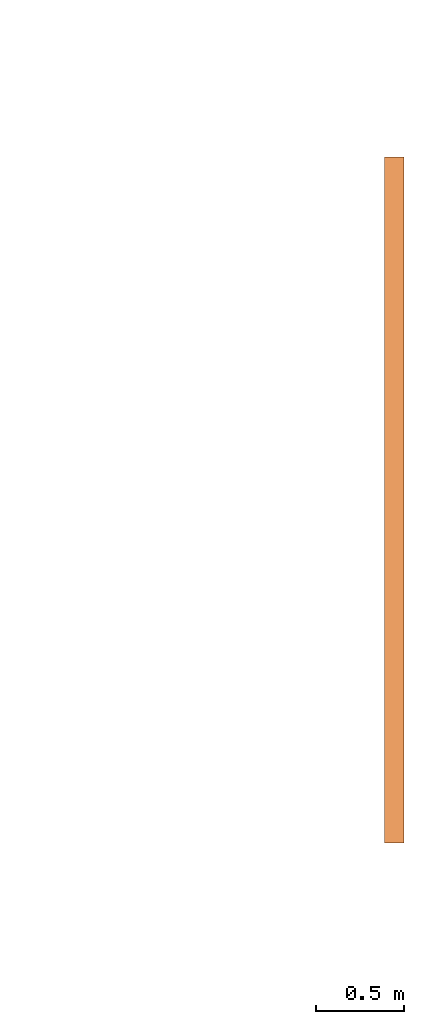
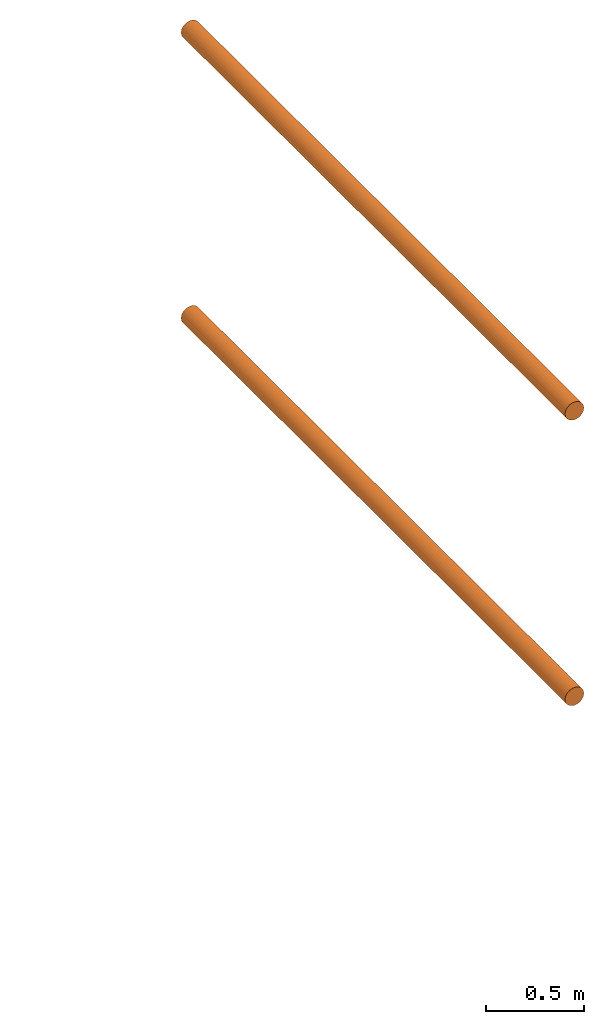
# One storey, part 5 of 5: 2 proxies.
"""IFC2X3 building model written with IfcOpenShell, lengths in metres."""

from ifc_helpers import new_model, entity, si_unit, converted_unit, frame, origin, place, context, subcontext, project, spatial, faceted_brep, material, element, save


model = new_model("IFC2X3")

# Units and contexts
model_context = context("Model", 3, precision=1e-05, world=origin())
body_context = subcontext(model_context, "Body", "Model", "MODEL_VIEW")
ifc_project = project(units=[si_unit("LENGTHUNIT", "METRE"), si_unit("AREAUNIT", "SQUARE_METRE"), si_unit("VOLUMEUNIT", "CUBIC_METRE"), converted_unit("PLANEANGLEUNIT", "DEGREE", entity("IfcPlaneAngleMeasure", 0.0174532925199433), si_unit("PLANEANGLEUNIT", "RADIAN"), dimensions=[0, 0, 0, 0, 0, 0, 0])], contexts=[model_context])

# Site, building, storey
site_placement = place(None, frame((2.0, 7.0, 6.0)))
site = spatial("IfcSite", under=ifc_project, at=site_placement, CompositionType="ELEMENT")
building_placement = place(site_placement, origin())
building = spatial("IfcBuilding", under=site, at=building_placement, Name="de", CompositionType="ELEMENT")
storey_placement = place(building_placement, frame((0.0, 0.0, 4.0)))
storey = spatial("IfcBuildingStorey", under=building, at=storey_placement, CompositionType="ELEMENT", Elevation=4.0)

# Proxies
ifc_material_1 = material()
proxy_1_placement = place(storey_placement, frame((7.751510837974278, 2.468964102564105, 2.833089238362359)))
element("IfcBuildingElementProxy", 1, at=proxy_1_placement, inside=storey, material=ifc_material_1, context=body_context, shape_type="Brep", body=[
    faceted_brep([(0.11, 2.273736754432321e-16, 0.05500000000000001), (0.1081259204458988, 2.273736754432321e-16, 0.04076495251936138), (0.1026313972081441, 2.273736754432321e-16, 0.02750000000000001), (0.09389087296526015, 2.273736754432321e-16, 0.01610912703473991), (0.08250000000000002, 2.273736754432321e-16, 0.007368602791855885), (0.06923504748063866, 2.273736754432321e-16, 0.00187407955410125), (0.05500000000000003, 2.273736754432321e-16, 0.0), (0.0407649525193614, 2.273736754432321e-16, 0.001874079554101236), (0.02750000000000004, 2.273736754432321e-16, 0.007368602791855849), (0.01610912703473991, 2.273736754432321e-16, 0.01610912703473987), (0.007368602791855913, 2.273736754432321e-16, 0.02749999999999994), (0.001874079554101257, 2.273736754432321e-16, 0.04076495251936132), (0.0, 2.273736754432321e-16, 0.05499999999999995), (0.001874079554101236, 2.273736754432321e-16, 0.06923504748063862), (0.007368602791855849, 2.273736754432321e-16, 0.08249999999999996), (0.01610912703473984, 2.273736754432321e-16, 0.09389087296526008), (0.02749999999999994, 2.273736754432321e-16, 0.1026313972081441), (0.04076495251936132, 2.273736754432321e-16, 0.1081259204458988), (0.055, 2.273736754432321e-16, 0.11), (0.06923504748063865, 2.273736754432321e-16, 0.1081259204458988), (0.0825, 2.273736754432321e-16, 0.1026313972081441), (0.09389087296526012, 2.273736754432321e-16, 0.09389087296526012), (0.1026313972081441, 2.273736754432321e-16, 0.0825), (0.1081259204458988, 2.273736754432321e-16, 0.06923504748063866), (0.11, 3.9, 0.055), (0.1081259204458988, 3.9, 0.06923504748063866), (0.1026313972081441, 3.9, 0.0825), (0.09389087296526012, 3.9, 0.09389087296526012), (0.0825, 3.9, 0.1026313972081441), (0.06923504748063865, 3.9, 0.1081259204458988), (0.055, 3.9, 0.11), (0.04076495251936132, 3.9, 0.1081259204458988), (0.02749999999999994, 3.9, 0.1026313972081441), (0.01610912703473984, 3.9, 0.09389087296526008), (0.007368602791855849, 3.9, 0.08249999999999996), (0.001874079554101236, 3.9, 0.06923504748063862), (0.0, 3.9, 0.05499999999999995), (0.001874079554101257, 3.9, 0.04076495251936132), (0.007368602791855913, 3.9, 0.02749999999999994), (0.01610912703473991, 3.9, 0.01610912703473987), (0.02750000000000004, 3.9, 0.007368602791855849), (0.0407649525193614, 3.9, 0.001874079554101236), (0.05500000000000003, 3.9, 0.0), (0.06923504748063866, 3.9, 0.00187407955410125), (0.08250000000000002, 3.9, 0.007368602791855885), (0.09389087296526015, 3.9, 0.01610912703473991), (0.1026313972081441, 3.9, 0.02750000000000001), (0.1081259204458988, 3.9, 0.04076495251936138), (0.055, 3.9, 0.11), (0.055, 2.273736754432321e-16, 0.11), (0.04076495251936132, 2.273736754432321e-16, 0.1081259204458988), (0.04076495251936132, 3.9, 0.1081259204458988), (0.04076495251936132, 3.9, 0.1081259204458988), (0.04076495251936132, 2.273736754432321e-16, 0.1081259204458988), (0.02749999999999994, 2.273736754432321e-16, 0.1026313972081441), (0.02749999999999994, 3.9, 0.1026313972081441), (0.02749999999999994, 3.9, 0.1026313972081441), (0.02749999999999994, 2.273736754432321e-16, 0.1026313972081441), (0.01610912703473984, 2.273736754432321e-16, 0.09389087296526008), (0.01610912703473984, 3.9, 0.09389087296526008), (0.01610912703473984, 3.9, 0.09389087296526008), (0.01610912703473984, 2.273736754432321e-16, 0.09389087296526008), (0.007368602791855849, 2.273736754432321e-16, 0.08249999999999996), (0.007368602791855849, 3.9, 0.08249999999999996), (0.007368602791855849, 3.9, 0.08249999999999996), (0.007368602791855849, 2.273736754432321e-16, 0.08249999999999996), (0.001874079554101236, 2.273736754432321e-16, 0.06923504748063862), (0.001874079554101236, 3.9, 0.06923504748063862), (0.001874079554101236, 3.9, 0.06923504748063862), (0.001874079554101236, 2.273736754432321e-16, 0.06923504748063862), (0.0, 2.273736754432321e-16, 0.05499999999999995), (0.0, 3.9, 0.05499999999999995), (0.0, 3.9, 0.05499999999999995), (0.0, 2.273736754432321e-16, 0.05499999999999995), (0.001874079554101257, 2.273736754432321e-16, 0.04076495251936132), (0.001874079554101257, 3.9, 0.04076495251936132), (0.001874079554101257, 3.9, 0.04076495251936132), (0.001874079554101257, 2.273736754432321e-16, 0.04076495251936132), (0.007368602791855913, 2.273736754432321e-16, 0.02749999999999994), (0.007368602791855913, 3.9, 0.02749999999999994), (0.007368602791855913, 3.9, 0.02749999999999994), (0.007368602791855913, 2.273736754432321e-16, 0.02749999999999994), (0.01610912703473991, 2.273736754432321e-16, 0.01610912703473987), (0.01610912703473991, 3.9, 0.01610912703473987), (0.01610912703473991, 3.9, 0.01610912703473987), (0.01610912703473991, 2.273736754432321e-16, 0.01610912703473987), (0.02750000000000004, 2.273736754432321e-16, 0.007368602791855849), (0.02750000000000004, 3.9, 0.007368602791855849), (0.02750000000000004, 3.9, 0.007368602791855849), (0.02750000000000004, 2.273736754432321e-16, 0.007368602791855849), (0.0407649525193614, 2.273736754432321e-16, 0.001874079554101236), (0.0407649525193614, 3.9, 0.001874079554101236), (0.0407649525193614, 3.9, 0.001874079554101236), (0.0407649525193614, 2.273736754432321e-16, 0.001874079554101236), (0.05500000000000003, 2.273736754432321e-16, 0.0), (0.05500000000000003, 3.9, 0.0), (0.05500000000000003, 3.9, 0.0), (0.05500000000000003, 2.273736754432321e-16, 0.0), (0.06923504748063866, 2.273736754432321e-16, 0.00187407955410125), (0.06923504748063866, 3.9, 0.00187407955410125), (0.06923504748063866, 3.9, 0.00187407955410125), (0.06923504748063866, 2.273736754432321e-16, 0.00187407955410125), (0.08250000000000002, 2.273736754432321e-16, 0.007368602791855885), (0.08250000000000002, 3.9, 0.007368602791855885), (0.08250000000000002, 3.9, 0.007368602791855885), (0.08250000000000002, 2.273736754432321e-16, 0.007368602791855885), (0.09389087296526015, 2.273736754432321e-16, 0.01610912703473991), (0.09389087296526015, 3.9, 0.01610912703473991), (0.09389087296526015, 3.9, 0.01610912703473991), (0.09389087296526015, 2.273736754432321e-16, 0.01610912703473991), (0.1026313972081441, 2.273736754432321e-16, 0.02750000000000001), (0.1026313972081441, 3.9, 0.02750000000000001), (0.1026313972081441, 3.9, 0.02750000000000001), (0.1026313972081441, 2.273736754432321e-16, 0.02750000000000001), (0.1081259204458988, 2.273736754432321e-16, 0.04076495251936138), (0.1081259204458988, 3.9, 0.04076495251936138), (0.1081259204458988, 3.9, 0.04076495251936138), (0.1081259204458988, 2.273736754432321e-16, 0.04076495251936138), (0.11, 2.273736754432321e-16, 0.05500000000000001), (0.11, 3.9, 0.055), (0.11, 3.9, 0.055), (0.11, 2.273736754432321e-16, 0.05500000000000001), (0.1081259204458988, 2.273736754432321e-16, 0.06923504748063866), (0.1081259204458988, 3.9, 0.06923504748063866), (0.1081259204458988, 3.9, 0.06923504748063866), (0.1081259204458988, 2.273736754432321e-16, 0.06923504748063866), (0.1026313972081441, 2.273736754432321e-16, 0.0825), (0.1026313972081441, 3.9, 0.0825), (0.1026313972081441, 3.9, 0.0825), (0.1026313972081441, 2.273736754432321e-16, 0.0825), (0.09389087296526012, 2.273736754432321e-16, 0.09389087296526012), (0.09389087296526012, 3.9, 0.09389087296526012), (0.09389087296526012, 3.9, 0.09389087296526012), (0.09389087296526012, 2.273736754432321e-16, 0.09389087296526012), (0.0825, 2.273736754432321e-16, 0.1026313972081441), (0.0825, 3.9, 0.1026313972081441), (0.0825, 3.9, 0.1026313972081441), (0.0825, 2.273736754432321e-16, 0.1026313972081441), (0.06923504748063865, 2.273736754432321e-16, 0.1081259204458988), (0.06923504748063865, 3.9, 0.1081259204458988), (0.06923504748063865, 3.9, 0.1081259204458988), (0.06923504748063865, 2.273736754432321e-16, 0.1081259204458988), (0.055, 2.273736754432321e-16, 0.11), (0.055, 3.9, 0.11)], [[[0, 1, 2, 3, 4, 5, 6, 7, 8, 9, 10, 11, 12, 13, 14, 15, 16, 17, 18, 19, 20, 21, 22, 23]], [[24, 25, 26, 27, 28, 29, 30, 31, 32, 33, 34, 35, 36, 37, 38, 39, 40, 41, 42, 43, 44, 45, 46, 47]], [[48, 49, 50, 51]], [[52, 53, 54, 55]], [[56, 57, 58, 59]], [[60, 61, 62, 63]], [[64, 65, 66, 67]], [[68, 69, 70, 71]], [[72, 73, 74, 75]], [[76, 77, 78, 79]], [[80, 81, 82, 83]], [[84, 85, 86, 87]], [[88, 89, 90, 91]], [[92, 93, 94, 95]], [[96, 97, 98, 99]], [[100, 101, 102, 103]], [[104, 105, 106, 107]], [[108, 109, 110, 111]], [[112, 113, 114, 115]], [[116, 117, 118, 119]], [[120, 121, 122, 123]], [[124, 125, 126, 127]], [[128, 129, 130, 131]], [[132, 133, 134, 135]], [[136, 137, 138, 139]], [[140, 141, 142, 143]]], orient=[[False], [False], [False], [False], [False], [False], [False], [False], [False], [False], [False], [False], [False], [False], [False], [False], [False], [False], [False], [False], [False], [False], [False], [False], [False], [False]]),
])
ifc_material_2 = material()
proxy_2_placement = place(storey_placement, frame((7.751510837974278, 2.468964102564105, 1.063089238362359)))
element("IfcBuildingElementProxy", 2, at=proxy_2_placement, inside=storey, material=ifc_material_2, context=body_context, shape_type="Brep", body=[
    faceted_brep([(0.11, 2.273736754432321e-16, 0.05500000000000001), (0.1081259204458988, 2.273736754432321e-16, 0.04076495251936138), (0.1026313972081441, 2.273736754432321e-16, 0.02750000000000001), (0.09389087296526015, 2.273736754432321e-16, 0.01610912703473991), (0.08250000000000002, 2.273736754432321e-16, 0.007368602791855885), (0.06923504748063866, 2.273736754432321e-16, 0.00187407955410125), (0.05500000000000003, 2.273736754432321e-16, 0.0), (0.0407649525193614, 2.273736754432321e-16, 0.001874079554101236), (0.02750000000000004, 2.273736754432321e-16, 0.007368602791855849), (0.01610912703473991, 2.273736754432321e-16, 0.01610912703473987), (0.007368602791855913, 2.273736754432321e-16, 0.02749999999999994), (0.001874079554101257, 2.273736754432321e-16, 0.04076495251936132), (0.0, 2.273736754432321e-16, 0.05499999999999995), (0.001874079554101236, 2.273736754432321e-16, 0.06923504748063862), (0.007368602791855849, 2.273736754432321e-16, 0.08249999999999996), (0.01610912703473984, 2.273736754432321e-16, 0.09389087296526008), (0.02749999999999994, 2.273736754432321e-16, 0.1026313972081441), (0.04076495251936132, 2.273736754432321e-16, 0.1081259204458988), (0.055, 2.273736754432321e-16, 0.11), (0.06923504748063865, 2.273736754432321e-16, 0.1081259204458988), (0.0825, 2.273736754432321e-16, 0.1026313972081441), (0.09389087296526012, 2.273736754432321e-16, 0.09389087296526012), (0.1026313972081441, 2.273736754432321e-16, 0.0825), (0.1081259204458988, 2.273736754432321e-16, 0.06923504748063866), (0.11, 3.9, 0.055), (0.1081259204458988, 3.9, 0.06923504748063866), (0.1026313972081441, 3.9, 0.0825), (0.09389087296526012, 3.9, 0.09389087296526012), (0.0825, 3.9, 0.1026313972081441), (0.06923504748063865, 3.9, 0.1081259204458988), (0.055, 3.9, 0.11), (0.04076495251936132, 3.9, 0.1081259204458988), (0.02749999999999994, 3.9, 0.1026313972081441), (0.01610912703473984, 3.9, 0.09389087296526008), (0.007368602791855849, 3.9, 0.08249999999999996), (0.001874079554101236, 3.9, 0.06923504748063862), (0.0, 3.9, 0.05499999999999995), (0.001874079554101257, 3.9, 0.04076495251936132), (0.007368602791855913, 3.9, 0.02749999999999994), (0.01610912703473991, 3.9, 0.01610912703473987), (0.02750000000000004, 3.9, 0.007368602791855849), (0.0407649525193614, 3.9, 0.001874079554101236), (0.05500000000000003, 3.9, 0.0), (0.06923504748063866, 3.9, 0.00187407955410125), (0.08250000000000002, 3.9, 0.007368602791855885), (0.09389087296526015, 3.9, 0.01610912703473991), (0.1026313972081441, 3.9, 0.02750000000000001), (0.1081259204458988, 3.9, 0.04076495251936138), (0.055, 3.9, 0.11), (0.055, 2.273736754432321e-16, 0.11), (0.04076495251936132, 2.273736754432321e-16, 0.1081259204458988), (0.04076495251936132, 3.9, 0.1081259204458988), (0.04076495251936132, 3.9, 0.1081259204458988), (0.04076495251936132, 2.273736754432321e-16, 0.1081259204458988), (0.02749999999999994, 2.273736754432321e-16, 0.1026313972081441), (0.02749999999999994, 3.9, 0.1026313972081441), (0.02749999999999994, 3.9, 0.1026313972081441), (0.02749999999999994, 2.273736754432321e-16, 0.1026313972081441), (0.01610912703473984, 2.273736754432321e-16, 0.09389087296526008), (0.01610912703473984, 3.9, 0.09389087296526008), (0.01610912703473984, 3.9, 0.09389087296526008), (0.01610912703473984, 2.273736754432321e-16, 0.09389087296526008), (0.007368602791855849, 2.273736754432321e-16, 0.08249999999999996), (0.007368602791855849, 3.9, 0.08249999999999996), (0.007368602791855849, 3.9, 0.08249999999999996), (0.007368602791855849, 2.273736754432321e-16, 0.08249999999999996), (0.001874079554101236, 2.273736754432321e-16, 0.06923504748063862), (0.001874079554101236, 3.9, 0.06923504748063862), (0.001874079554101236, 3.9, 0.06923504748063862), (0.001874079554101236, 2.273736754432321e-16, 0.06923504748063862), (0.0, 2.273736754432321e-16, 0.05499999999999995), (0.0, 3.9, 0.05499999999999995), (0.0, 3.9, 0.05499999999999995), (0.0, 2.273736754432321e-16, 0.05499999999999995), (0.001874079554101257, 2.273736754432321e-16, 0.04076495251936132), (0.001874079554101257, 3.9, 0.04076495251936132), (0.001874079554101257, 3.9, 0.04076495251936132), (0.001874079554101257, 2.273736754432321e-16, 0.04076495251936132), (0.007368602791855913, 2.273736754432321e-16, 0.02749999999999994), (0.007368602791855913, 3.9, 0.02749999999999994), (0.007368602791855913, 3.9, 0.02749999999999994), (0.007368602791855913, 2.273736754432321e-16, 0.02749999999999994), (0.01610912703473991, 2.273736754432321e-16, 0.01610912703473987), (0.01610912703473991, 3.9, 0.01610912703473987), (0.01610912703473991, 3.9, 0.01610912703473987), (0.01610912703473991, 2.273736754432321e-16, 0.01610912703473987), (0.02750000000000004, 2.273736754432321e-16, 0.007368602791855849), (0.02750000000000004, 3.9, 0.007368602791855849), (0.02750000000000004, 3.9, 0.007368602791855849), (0.02750000000000004, 2.273736754432321e-16, 0.007368602791855849), (0.0407649525193614, 2.273736754432321e-16, 0.001874079554101236), (0.0407649525193614, 3.9, 0.001874079554101236), (0.0407649525193614, 3.9, 0.001874079554101236), (0.0407649525193614, 2.273736754432321e-16, 0.001874079554101236), (0.05500000000000003, 2.273736754432321e-16, 0.0), (0.05500000000000003, 3.9, 0.0), (0.05500000000000003, 3.9, 0.0), (0.05500000000000003, 2.273736754432321e-16, 0.0), (0.06923504748063866, 2.273736754432321e-16, 0.00187407955410125), (0.06923504748063866, 3.9, 0.00187407955410125), (0.06923504748063866, 3.9, 0.00187407955410125), (0.06923504748063866, 2.273736754432321e-16, 0.00187407955410125), (0.08250000000000002, 2.273736754432321e-16, 0.007368602791855885), (0.08250000000000002, 3.9, 0.007368602791855885), (0.08250000000000002, 3.9, 0.007368602791855885), (0.08250000000000002, 2.273736754432321e-16, 0.007368602791855885), (0.09389087296526015, 2.273736754432321e-16, 0.01610912703473991), (0.09389087296526015, 3.9, 0.01610912703473991), (0.09389087296526015, 3.9, 0.01610912703473991), (0.09389087296526015, 2.273736754432321e-16, 0.01610912703473991), (0.1026313972081441, 2.273736754432321e-16, 0.02750000000000001), (0.1026313972081441, 3.9, 0.02750000000000001), (0.1026313972081441, 3.9, 0.02750000000000001), (0.1026313972081441, 2.273736754432321e-16, 0.02750000000000001), (0.1081259204458988, 2.273736754432321e-16, 0.04076495251936138), (0.1081259204458988, 3.9, 0.04076495251936138), (0.1081259204458988, 3.9, 0.04076495251936138), (0.1081259204458988, 2.273736754432321e-16, 0.04076495251936138), (0.11, 2.273736754432321e-16, 0.05500000000000001), (0.11, 3.9, 0.055), (0.11, 3.9, 0.055), (0.11, 2.273736754432321e-16, 0.05500000000000001), (0.1081259204458988, 2.273736754432321e-16, 0.06923504748063866), (0.1081259204458988, 3.9, 0.06923504748063866), (0.1081259204458988, 3.9, 0.06923504748063866), (0.1081259204458988, 2.273736754432321e-16, 0.06923504748063866), (0.1026313972081441, 2.273736754432321e-16, 0.0825), (0.1026313972081441, 3.9, 0.0825), (0.1026313972081441, 3.9, 0.0825), (0.1026313972081441, 2.273736754432321e-16, 0.0825), (0.09389087296526012, 2.273736754432321e-16, 0.09389087296526012), (0.09389087296526012, 3.9, 0.09389087296526012), (0.09389087296526012, 3.9, 0.09389087296526012), (0.09389087296526012, 2.273736754432321e-16, 0.09389087296526012), (0.0825, 2.273736754432321e-16, 0.1026313972081441), (0.0825, 3.9, 0.1026313972081441), (0.0825, 3.9, 0.1026313972081441), (0.0825, 2.273736754432321e-16, 0.1026313972081441), (0.06923504748063865, 2.273736754432321e-16, 0.1081259204458988), (0.06923504748063865, 3.9, 0.1081259204458988), (0.06923504748063865, 3.9, 0.1081259204458988), (0.06923504748063865, 2.273736754432321e-16, 0.1081259204458988), (0.055, 2.273736754432321e-16, 0.11), (0.055, 3.9, 0.11)], [[[0, 1, 2, 3, 4, 5, 6, 7, 8, 9, 10, 11, 12, 13, 14, 15, 16, 17, 18, 19, 20, 21, 22, 23]], [[24, 25, 26, 27, 28, 29, 30, 31, 32, 33, 34, 35, 36, 37, 38, 39, 40, 41, 42, 43, 44, 45, 46, 47]], [[48, 49, 50, 51]], [[52, 53, 54, 55]], [[56, 57, 58, 59]], [[60, 61, 62, 63]], [[64, 65, 66, 67]], [[68, 69, 70, 71]], [[72, 73, 74, 75]], [[76, 77, 78, 79]], [[80, 81, 82, 83]], [[84, 85, 86, 87]], [[88, 89, 90, 91]], [[92, 93, 94, 95]], [[96, 97, 98, 99]], [[100, 101, 102, 103]], [[104, 105, 106, 107]], [[108, 109, 110, 111]], [[112, 113, 114, 115]], [[116, 117, 118, 119]], [[120, 121, 122, 123]], [[124, 125, 126, 127]], [[128, 129, 130, 131]], [[132, 133, 134, 135]], [[136, 137, 138, 139]], [[140, 141, 142, 143]]], orient=[[False], [False], [False], [False], [False], [False], [False], [False], [False], [False], [False], [False], [False], [False], [False], [False], [False], [False], [False], [False], [False], [False], [False], [False], [False], [False]]),
])

save(model, "model.ifc")
